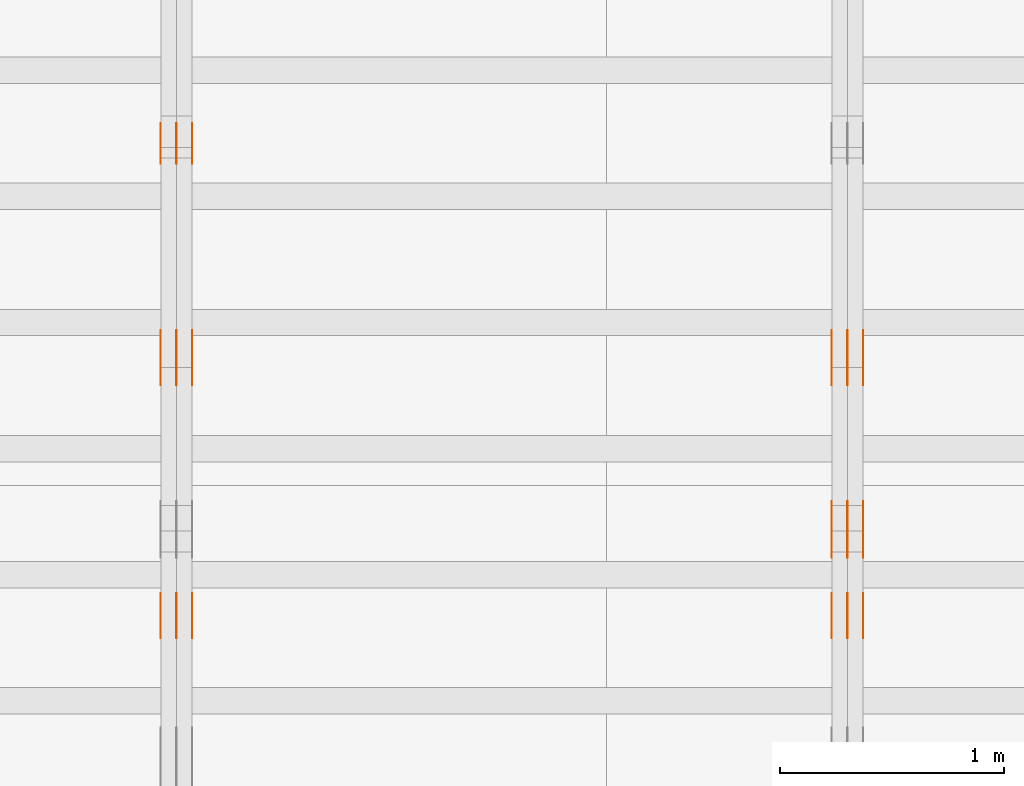
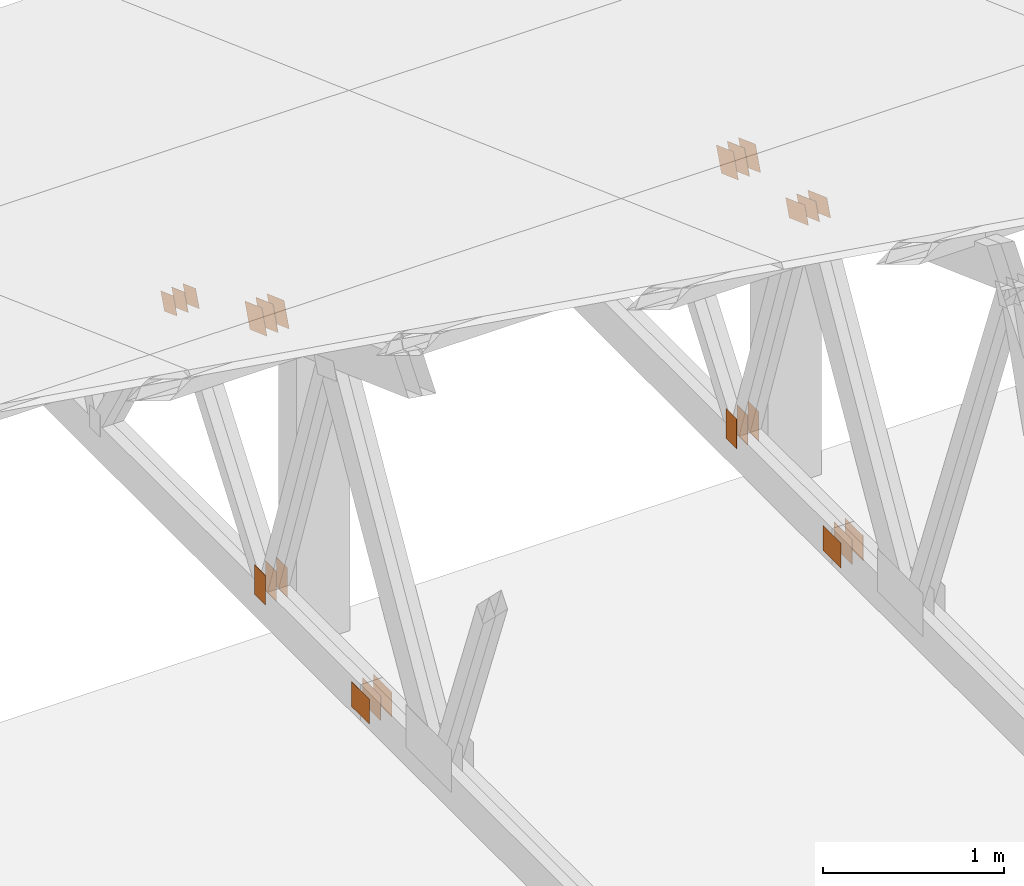
# One storey, part 126 of 189: 32 proxies.
"""IFC2X3 building model written with IfcOpenShell, lengths in millimetres."""

from ifc_helpers import new_model, entity, si_unit, converted_unit, derived_unit, direction, frame, origin, origin_2d_with_axis, place, context, subcontext, project, spatial, polyline, rectangle, outline, extrude, source, transform, mapped, material, type_object, type_shapes, element, save


model = new_model("IFC2X3")

# Units and contexts
model_context = context("Model", 3, precision=0.01, world=origin(), true_north=direction((6.12303176911189e-17, 1.0)))
body_context = subcontext(model_context, "Body", "Model", "MODEL_VIEW")
ifc_project = project(units=[si_unit("LENGTHUNIT", "METRE", prefix="MILLI"), si_unit("AREAUNIT", "SQUARE_METRE"), si_unit("VOLUMEUNIT", "CUBIC_METRE"), converted_unit("PLANEANGLEUNIT", "DEGREE", entity("IfcRatioMeasure", 0.0174532925199433), si_unit("PLANEANGLEUNIT", "RADIAN"), dimensions=[0, 0, 0, 0, 0, 0, 0]), si_unit("MASSUNIT", "GRAM", prefix="KILO"), derived_unit("MASSDENSITYUNIT", [(si_unit("MASSUNIT", "GRAM", prefix="KILO"), 1), (si_unit("LENGTHUNIT", "METRE"), -3)]), si_unit("TIMEUNIT", "SECOND"), si_unit("FREQUENCYUNIT", "HERTZ"), si_unit("THERMODYNAMICTEMPERATUREUNIT", "DEGREE_CELSIUS"), derived_unit("THERMALTRANSMITTANCEUNIT", [(si_unit("MASSUNIT", "GRAM", prefix="KILO"), 1), (si_unit("THERMODYNAMICTEMPERATUREUNIT", "KELVIN"), -1), (si_unit("TIMEUNIT", "SECOND"), -3)]), derived_unit("VOLUMETRICFLOWRATEUNIT", [(si_unit("LENGTHUNIT", "METRE"), 3), (si_unit("TIMEUNIT", "SECOND"), -1)]), si_unit("ELECTRICCURRENTUNIT", "AMPERE"), si_unit("ELECTRICVOLTAGEUNIT", "VOLT"), si_unit("POWERUNIT", "WATT"), si_unit("FORCEUNIT", "NEWTON"), si_unit("ILLUMINANCEUNIT", "LUX"), si_unit("LUMINOUSFLUXUNIT", "LUMEN"), si_unit("LUMINOUSINTENSITYUNIT", "CANDELA"), derived_unit("USERDEFINED", [(si_unit("MASSUNIT", "GRAM", prefix="KILO"), -1), (si_unit("LENGTHUNIT", "METRE"), -2), (si_unit("TIMEUNIT", "SECOND"), 3), (si_unit("LUMINOUSFLUXUNIT", "LUMEN"), 1)]), derived_unit("LINEARVELOCITYUNIT", [(si_unit("LENGTHUNIT", "METRE"), 1), (si_unit("TIMEUNIT", "SECOND"), -1)]), si_unit("PRESSUREUNIT", "PASCAL"), derived_unit("USERDEFINED", [(si_unit("LENGTHUNIT", "METRE"), -2), (si_unit("MASSUNIT", "GRAM", prefix="KILO"), 1), (si_unit("TIMEUNIT", "SECOND"), -2)])], contexts=[model_context])

# Site, building, storey
site_placement = place(None, origin())
site = spatial("IfcSite", under=ifc_project, at=site_placement, CompositionType="ELEMENT")
building_placement = place(site_placement, origin())
building = spatial("IfcBuilding", under=site, at=building_placement, CompositionType="ELEMENT")
storey_placement = place(building_placement, origin())
storey = spatial("IfcBuildingStorey", under=building, at=storey_placement, Name="Default", CompositionType="ELEMENT", Elevation=0.0)

# Proxies
ifc_material_1 = material(Name="IfcSurfaceStyle #106478")
building_element_proxy_type_1 = type_object("IfcBuildingElementProxyType", PredefinedType="NOTDEFINED", material=ifc_material_1)
shared_shape_1 = source(origin(), body_context, "Body", "SweptSolid", [
    extrude(outline(polyline([(-112.499846801582, -59.999986193028), (112.499924372729, -59.999986193028), (112.499888552087, 59.999986193028), (-112.499966123235, 59.999986193028), (-112.499846801582, -59.999986193028)])), frame((112.499989807712, 60.0001003787081, 0.0), z_axis=(0.0, 0.0, 1.0), x_axis=(-1.0, 0.0, 0.0)), (0.0, 0.0, 1.0), 1.3),
])
type_shapes(building_element_proxy_type_1, [shared_shape_1])
proxy_1_placement = place(building_placement, frame((18301.3, 24040.8868138992, 2049.61031693104), z_axis=(-1.0, 0.0, 0.0), x_axis=(0.0, -0.939692620785908, 0.342020143325669)))
element("IfcBuildingElementProxy", 1, at=proxy_1_placement, inside=storey, type_object=building_element_proxy_type_1, material=ifc_material_1, context=body_context, shape_type="MappedRepresentation", body=[
    mapped(shared_shape_1, transform((0.0, 0.0, 0.0), scale=1.0)),
])
ifc_material_2 = material(Name="IfcSurfaceStyle #106421")
building_element_proxy_type_2 = type_object("IfcBuildingElementProxyType", PredefinedType="NOTDEFINED", material=ifc_material_2)
shared_shape_2 = source(origin(), body_context, "Body", "SweptSolid", [
    extrude(outline(polyline([(-112.499846801582, -59.999986193028), (112.499924372729, -59.999986193028), (112.499888552087, 59.999986193028), (-112.499966123235, 59.999986193028), (-112.499846801582, -59.999986193028)])), frame((112.499989807712, 60.0001003787081, 0.0), z_axis=(0.0, 0.0, 1.0), x_axis=(-1.0, 0.0, 0.0)), (0.0, 0.0, 1.0), 1.29999999999998),
])
type_shapes(building_element_proxy_type_2, [shared_shape_2])
proxy_2_placement = place(building_placement, frame((18230.0, 24040.8868138992, 2049.61031693104), z_axis=(-1.0, 0.0, 0.0), x_axis=(0.0, -0.939692620785908, 0.342020143325669)))
element("IfcBuildingElementProxy", 2, at=proxy_2_placement, inside=storey, type_object=building_element_proxy_type_2, material=ifc_material_2, context=body_context, shape_type="MappedRepresentation", body=[
    mapped(shared_shape_2, transform((0.0, 0.0, 0.0), scale=1.0)),
])
ifc_material_3 = material(Name="IfcSurfaceStyle #106364")
building_element_proxy_type_3 = type_object("IfcBuildingElementProxyType", PredefinedType="NOTDEFINED", material=ifc_material_3)
shared_shape_3 = source(origin(), body_context, "Body", "SweptSolid", [
    extrude(outline(polyline([(-112.499846801582, -59.999986193028), (112.499924372729, -59.999986193028), (112.499888552087, 59.999986193028), (-112.499966123235, 59.999986193028), (-112.499846801582, -59.999986193028)])), frame((112.499989807712, 60.0001003787081, 0.0), z_axis=(0.0, 0.0, 1.0), x_axis=(-1.0, 0.0, 0.0)), (0.0, 0.0, 1.0), 1.29999999999998),
])
type_shapes(building_element_proxy_type_3, [shared_shape_3])
proxy_3_placement = place(building_placement, frame((18231.3, 24040.8868138992, 2049.61031693104), z_axis=(-1.0, 0.0, 0.0), x_axis=(0.0, -0.939692620785908, 0.342020143325669)))
element("IfcBuildingElementProxy", 3, at=proxy_3_placement, inside=storey, type_object=building_element_proxy_type_3, material=ifc_material_3, context=body_context, shape_type="MappedRepresentation", body=[
    mapped(shared_shape_3, transform((0.0, 0.0, 0.0), scale=1.0)),
])
ifc_material_4 = material(Name="IfcSurfaceStyle #106307")
building_element_proxy_type_4 = type_object("IfcBuildingElementProxyType", PredefinedType="NOTDEFINED", material=ifc_material_4)
shared_shape_4 = source(origin(), body_context, "Body", "SweptSolid", [
    extrude(outline(polyline([(-112.499846801582, -59.999986193028), (112.499924372729, -59.999986193028), (112.499888552087, 59.999986193028), (-112.499966123235, 59.999986193028), (-112.499846801582, -59.999986193028)])), frame((112.499989807712, 60.0001003787081, 0.0), z_axis=(0.0, 0.0, 1.0), x_axis=(-1.0, 0.0, 0.0)), (0.0, 0.0, 1.0), 1.29999999999999),
])
type_shapes(building_element_proxy_type_4, [shared_shape_4])
proxy_4_placement = place(building_placement, frame((18160.0, 24040.8868138992, 2049.61031693104), z_axis=(-1.0, 0.0, 0.0), x_axis=(0.0, -0.939692620785908, 0.342020143325669)))
element("IfcBuildingElementProxy", 4, at=proxy_4_placement, inside=storey, type_object=building_element_proxy_type_4, material=ifc_material_4, context=body_context, shape_type="MappedRepresentation", body=[
    mapped(shared_shape_4, transform((0.0, 0.0, 0.0), scale=1.0)),
])
ifc_material_5 = material(Name="IfcSurfaceStyle #106250")
building_element_proxy_type_5 = type_object("IfcBuildingElementProxyType", PredefinedType="NOTDEFINED", material=ifc_material_5)
shared_shape_5 = source(origin(), body_context, "Body", "SweptSolid", [
    extrude(rectangle(XDim=200.0, YDim=120.0, at=origin_2d_with_axis()), frame((100.0, 60.0002296775929, 0.0), z_axis=(0.0, 0.0, 1.0), x_axis=(-1.0, 0.0, 0.0)), (0.0, 0.0, 1.0), 1.3),
])
type_shapes(building_element_proxy_type_5, [shared_shape_5])
proxy_5_placement = place(building_placement, frame((18301.3, 24619.3435203224, 145.0), z_axis=(-1.0, 0.0, 0.0), x_axis=(0.0, 0.0, 1.0)))
element("IfcBuildingElementProxy", 5, at=proxy_5_placement, inside=storey, type_object=building_element_proxy_type_5, material=ifc_material_5, context=body_context, shape_type="MappedRepresentation", body=[
    mapped(shared_shape_5, transform((0.0, 0.0, 0.0), scale=1.0)),
])
ifc_material_6 = material(Name="IfcSurfaceStyle #106193")
building_element_proxy_type_6 = type_object("IfcBuildingElementProxyType", PredefinedType="NOTDEFINED", material=ifc_material_6)
shared_shape_6 = source(origin(), body_context, "Body", "SweptSolid", [
    extrude(rectangle(XDim=200.0, YDim=120.0, at=origin_2d_with_axis()), frame((100.0, 60.0002296775929, 0.0), z_axis=(0.0, 0.0, 1.0), x_axis=(-1.0, 0.0, 0.0)), (0.0, 0.0, 1.0), 1.29999999999998),
])
type_shapes(building_element_proxy_type_6, [shared_shape_6])
proxy_6_placement = place(building_placement, frame((18230.0, 24619.3435203224, 145.0), z_axis=(-1.0, 0.0, 0.0), x_axis=(0.0, 0.0, 1.0)))
element("IfcBuildingElementProxy", 6, at=proxy_6_placement, inside=storey, type_object=building_element_proxy_type_6, material=ifc_material_6, context=body_context, shape_type="MappedRepresentation", body=[
    mapped(shared_shape_6, transform((0.0, 0.0, 0.0), scale=1.0)),
])
ifc_material_7 = material(Name="IfcSurfaceStyle #106136")
building_element_proxy_type_7 = type_object("IfcBuildingElementProxyType", PredefinedType="NOTDEFINED", material=ifc_material_7)
shared_shape_7 = source(origin(), body_context, "Body", "SweptSolid", [
    extrude(rectangle(XDim=200.0, YDim=120.0, at=origin_2d_with_axis()), frame((100.0, 60.0002296775929, 0.0), z_axis=(0.0, 0.0, 1.0), x_axis=(-1.0, 0.0, 0.0)), (0.0, 0.0, 1.0), 1.29999999999998),
])
type_shapes(building_element_proxy_type_7, [shared_shape_7])
proxy_7_placement = place(building_placement, frame((18231.3, 24619.3435203224, 145.0), z_axis=(-1.0, 0.0, 0.0), x_axis=(0.0, 0.0, 1.0)))
element("IfcBuildingElementProxy", 7, at=proxy_7_placement, inside=storey, type_object=building_element_proxy_type_7, material=ifc_material_7, context=body_context, shape_type="MappedRepresentation", body=[
    mapped(shared_shape_7, transform((0.0, 0.0, 0.0), scale=1.0)),
])
ifc_material_8 = material(Name="IfcSurfaceStyle #106079")
building_element_proxy_type_8 = type_object("IfcBuildingElementProxyType", PredefinedType="NOTDEFINED", material=ifc_material_8)
shared_shape_8 = source(origin(), body_context, "Body", "SweptSolid", [
    extrude(rectangle(XDim=200.0, YDim=120.0, at=origin_2d_with_axis()), frame((100.0, 60.0002296775929, 0.0), z_axis=(0.0, 0.0, 1.0), x_axis=(-1.0, 0.0, 0.0)), (0.0, 0.0, 1.0), 1.29999999999999),
])
type_shapes(building_element_proxy_type_8, [shared_shape_8])
proxy_8_placement = place(building_placement, frame((18160.0, 24619.3435203224, 145.0), z_axis=(-1.0, 0.0, 0.0), x_axis=(0.0, 0.0, 1.0)))
element("IfcBuildingElementProxy", 8, at=proxy_8_placement, inside=storey, type_object=building_element_proxy_type_8, material=ifc_material_8, context=body_context, shape_type="MappedRepresentation", body=[
    mapped(shared_shape_8, transform((0.0, 0.0, 0.0), scale=1.0)),
])
ifc_material_9 = material(Name="IfcSurfaceStyle #102602")
building_element_proxy_type_9 = type_object("IfcBuildingElementProxyType", PredefinedType="NOTDEFINED", material=ifc_material_9)
shared_shape_9 = source(origin(), body_context, "Body", "SweptSolid", [
    extrude(rectangle(XDim=200.0, YDim=168.0, at=origin_2d_with_axis()), frame((100.0, 84.0, 0.0), z_axis=(0.0, 0.0, 1.0), x_axis=(-1.0, 0.0, 0.0)), (0.0, 0.0, 1.0), 1.3),
])
type_shapes(building_element_proxy_type_9, [shared_shape_9])
proxy_9_placement = place(building_placement, frame((18301.3, 23470.0, 206.5), z_axis=(-1.0, 0.0, 0.0), x_axis=(0.0, 1.0, 0.0)))
element("IfcBuildingElementProxy", 9, at=proxy_9_placement, inside=storey, type_object=building_element_proxy_type_9, material=ifc_material_9, context=body_context, shape_type="MappedRepresentation", body=[
    mapped(shared_shape_9, transform((0.0, 0.0, 0.0), scale=1.0)),
])
ifc_material_10 = material(Name="IfcSurfaceStyle #102545")
building_element_proxy_type_10 = type_object("IfcBuildingElementProxyType", PredefinedType="NOTDEFINED", material=ifc_material_10)
shared_shape_10 = source(origin(), body_context, "Body", "SweptSolid", [
    extrude(rectangle(XDim=200.0, YDim=168.0, at=origin_2d_with_axis()), frame((100.0, 84.0, 0.0), z_axis=(0.0, 0.0, 1.0), x_axis=(-1.0, 0.0, 0.0)), (0.0, 0.0, 1.0), 1.29999999999998),
])
type_shapes(building_element_proxy_type_10, [shared_shape_10])
proxy_10_placement = place(building_placement, frame((18230.0, 23470.0, 206.5), z_axis=(-1.0, 0.0, 0.0), x_axis=(0.0, 1.0, 0.0)))
element("IfcBuildingElementProxy", 10, at=proxy_10_placement, inside=storey, type_object=building_element_proxy_type_10, material=ifc_material_10, context=body_context, shape_type="MappedRepresentation", body=[
    mapped(shared_shape_10, transform((0.0, 0.0, 0.0), scale=1.0)),
])
ifc_material_11 = material(Name="IfcSurfaceStyle #102488")
building_element_proxy_type_11 = type_object("IfcBuildingElementProxyType", PredefinedType="NOTDEFINED", material=ifc_material_11)
shared_shape_11 = source(origin(), body_context, "Body", "SweptSolid", [
    extrude(rectangle(XDim=200.0, YDim=168.0, at=origin_2d_with_axis()), frame((100.0, 84.0, 0.0), z_axis=(0.0, 0.0, 1.0), x_axis=(-1.0, 0.0, 0.0)), (0.0, 0.0, 1.0), 1.29999999999998),
])
type_shapes(building_element_proxy_type_11, [shared_shape_11])
proxy_11_placement = place(building_placement, frame((18231.3, 23470.0, 206.5), z_axis=(-1.0, 0.0, 0.0), x_axis=(0.0, 1.0, 0.0)))
element("IfcBuildingElementProxy", 11, at=proxy_11_placement, inside=storey, type_object=building_element_proxy_type_11, material=ifc_material_11, context=body_context, shape_type="MappedRepresentation", body=[
    mapped(shared_shape_11, transform((0.0, 0.0, 0.0), scale=1.0)),
])
ifc_material_12 = material(Name="IfcSurfaceStyle #102431")
building_element_proxy_type_12 = type_object("IfcBuildingElementProxyType", PredefinedType="NOTDEFINED", material=ifc_material_12)
shared_shape_12 = source(origin(), body_context, "Body", "SweptSolid", [
    extrude(rectangle(XDim=200.0, YDim=168.0, at=origin_2d_with_axis()), frame((100.0, 84.0, 0.0), z_axis=(0.0, 0.0, 1.0), x_axis=(-1.0, 0.0, 0.0)), (0.0, 0.0, 1.0), 1.29999999999999),
])
type_shapes(building_element_proxy_type_12, [shared_shape_12])
proxy_12_placement = place(building_placement, frame((18160.0, 23470.0, 206.5), z_axis=(-1.0, 0.0, 0.0), x_axis=(0.0, 1.0, 0.0)))
element("IfcBuildingElementProxy", 12, at=proxy_12_placement, inside=storey, type_object=building_element_proxy_type_12, material=ifc_material_12, context=body_context, shape_type="MappedRepresentation", body=[
    mapped(shared_shape_12, transform((0.0, 0.0, 0.0), scale=1.0)),
])
ifc_material_13 = material(Name="IfcSurfaceStyle #100442")
building_element_proxy_type_13 = type_object("IfcBuildingElementProxyType", PredefinedType="NOTDEFINED", material=ifc_material_13)
shared_shape_13 = source(origin(), body_context, "Body", "SweptSolid", [
    extrude(outline(polyline([(-99.9999065788418, -84.0000755647729), (99.9999734279406, -84.0000755647729), (99.9999483293475, 84.000075564773), (-100.000015178446, 84.000075564773), (-99.9999065788418, -84.0000755647729)])), frame((100.000157783747, 84.0001144608011, 0.0), z_axis=(0.0, 0.0, 1.0), x_axis=(-1.0, 0.0, 0.0)), (0.0, 0.0, 1.0), 1.3),
])
type_shapes(building_element_proxy_type_13, [shared_shape_13])
proxy_13_placement = place(building_placement, frame((18301.3, 24788.4767593228, 1895.10136879206), z_axis=(-1.0, 0.0, 0.0), x_axis=(0.0, -0.939692620785908, 0.342020143325669)))
element("IfcBuildingElementProxy", 13, at=proxy_13_placement, inside=storey, type_object=building_element_proxy_type_13, material=ifc_material_13, context=body_context, shape_type="MappedRepresentation", body=[
    mapped(shared_shape_13, transform((0.0, 0.0, 0.0), scale=1.0)),
])
ifc_material_14 = material(Name="IfcSurfaceStyle #100385")
building_element_proxy_type_14 = type_object("IfcBuildingElementProxyType", PredefinedType="NOTDEFINED", material=ifc_material_14)
shared_shape_14 = source(origin(), body_context, "Body", "SweptSolid", [
    extrude(outline(polyline([(-99.9999065788418, -84.0000755647729), (99.9999734279406, -84.0000755647729), (99.9999483293475, 84.000075564773), (-100.000015178446, 84.000075564773), (-99.9999065788418, -84.0000755647729)])), frame((100.000157783747, 84.0001144608011, 0.0), z_axis=(0.0, 0.0, 1.0), x_axis=(-1.0, 0.0, 0.0)), (0.0, 0.0, 1.0), 1.29999999999998),
])
type_shapes(building_element_proxy_type_14, [shared_shape_14])
proxy_14_placement = place(building_placement, frame((18230.0, 24788.4767593228, 1895.10136879206), z_axis=(-1.0, 0.0, 0.0), x_axis=(0.0, -0.939692620785908, 0.342020143325669)))
element("IfcBuildingElementProxy", 14, at=proxy_14_placement, inside=storey, type_object=building_element_proxy_type_14, material=ifc_material_14, context=body_context, shape_type="MappedRepresentation", body=[
    mapped(shared_shape_14, transform((0.0, 0.0, 0.0), scale=1.0)),
])
ifc_material_15 = material(Name="IfcSurfaceStyle #100328")
building_element_proxy_type_15 = type_object("IfcBuildingElementProxyType", PredefinedType="NOTDEFINED", material=ifc_material_15)
shared_shape_15 = source(origin(), body_context, "Body", "SweptSolid", [
    extrude(outline(polyline([(-99.9999065788418, -84.0000755647729), (99.9999734279406, -84.0000755647729), (99.9999483293475, 84.000075564773), (-100.000015178446, 84.000075564773), (-99.9999065788418, -84.0000755647729)])), frame((100.000157783747, 84.0001144608011, 0.0), z_axis=(0.0, 0.0, 1.0), x_axis=(-1.0, 0.0, 0.0)), (0.0, 0.0, 1.0), 1.29999999999998),
])
type_shapes(building_element_proxy_type_15, [shared_shape_15])
proxy_15_placement = place(building_placement, frame((18231.3, 24788.4767593228, 1895.10136879206), z_axis=(-1.0, 0.0, 0.0), x_axis=(0.0, -0.939692620785908, 0.342020143325669)))
element("IfcBuildingElementProxy", 15, at=proxy_15_placement, inside=storey, type_object=building_element_proxy_type_15, material=ifc_material_15, context=body_context, shape_type="MappedRepresentation", body=[
    mapped(shared_shape_15, transform((0.0, 0.0, 0.0), scale=1.0)),
])
ifc_material_16 = material(Name="IfcSurfaceStyle #100271")
building_element_proxy_type_16 = type_object("IfcBuildingElementProxyType", PredefinedType="NOTDEFINED", material=ifc_material_16)
shared_shape_16 = source(origin(), body_context, "Body", "SweptSolid", [
    extrude(outline(polyline([(-99.9999065788418, -84.0000755647729), (99.9999734279406, -84.0000755647729), (99.9999483293475, 84.000075564773), (-100.000015178446, 84.000075564773), (-99.9999065788418, -84.0000755647729)])), frame((100.000157783747, 84.0001144608011, 0.0), z_axis=(0.0, 0.0, 1.0), x_axis=(-1.0, 0.0, 0.0)), (0.0, 0.0, 1.0), 1.29999999999999),
])
type_shapes(building_element_proxy_type_16, [shared_shape_16])
proxy_16_placement = place(building_placement, frame((18160.0, 24788.4767593228, 1895.10136879206), z_axis=(-1.0, 0.0, 0.0), x_axis=(0.0, -0.939692620785908, 0.342020143325669)))
element("IfcBuildingElementProxy", 16, at=proxy_16_placement, inside=storey, type_object=building_element_proxy_type_16, material=ifc_material_16, context=body_context, shape_type="MappedRepresentation", body=[
    mapped(shared_shape_16, transform((0.0, 0.0, 0.0), scale=1.0)),
])
ifc_material_17 = material(Name="IfcSurfaceStyle #90460")
building_element_proxy_type_17 = type_object("IfcBuildingElementProxyType", PredefinedType="NOTDEFINED", material=ifc_material_17)
shared_shape_17 = source(origin(), body_context, "Body", "SweptSolid", [
    extrude(rectangle(XDim=200.0, YDim=120.0, at=origin_2d_with_axis()), frame((100.0, 60.0002296775929, 0.0), z_axis=(0.0, 0.0, 1.0), x_axis=(-1.0, 0.0, 0.0)), (0.0, 0.0, 1.0), 1.3),
])
type_shapes(building_element_proxy_type_17, [shared_shape_17])
proxy_17_placement = place(building_placement, frame((15301.3, 24619.3435203224, 145.0), z_axis=(-1.0, 0.0, 0.0), x_axis=(0.0, 0.0, 1.0)))
element("IfcBuildingElementProxy", 17, at=proxy_17_placement, inside=storey, type_object=building_element_proxy_type_17, material=ifc_material_17, context=body_context, shape_type="MappedRepresentation", body=[
    mapped(shared_shape_17, transform((0.0, 0.0, 0.0), scale=1.0)),
])
ifc_material_18 = material(Name="IfcSurfaceStyle #90403")
building_element_proxy_type_18 = type_object("IfcBuildingElementProxyType", PredefinedType="NOTDEFINED", material=ifc_material_18)
shared_shape_18 = source(origin(), body_context, "Body", "SweptSolid", [
    extrude(rectangle(XDim=200.0, YDim=120.0, at=origin_2d_with_axis()), frame((100.0, 60.0002296775929, 0.0), z_axis=(0.0, 0.0, 1.0), x_axis=(-1.0, 0.0, 0.0)), (0.0, 0.0, 1.0), 1.29999999999998),
])
type_shapes(building_element_proxy_type_18, [shared_shape_18])
proxy_18_placement = place(building_placement, frame((15230.0, 24619.3435203224, 145.0), z_axis=(-1.0, 0.0, 0.0), x_axis=(0.0, 0.0, 1.0)))
element("IfcBuildingElementProxy", 18, at=proxy_18_placement, inside=storey, type_object=building_element_proxy_type_18, material=ifc_material_18, context=body_context, shape_type="MappedRepresentation", body=[
    mapped(shared_shape_18, transform((0.0, 0.0, 0.0), scale=1.0)),
])
ifc_material_19 = material(Name="IfcSurfaceStyle #90346")
building_element_proxy_type_19 = type_object("IfcBuildingElementProxyType", PredefinedType="NOTDEFINED", material=ifc_material_19)
shared_shape_19 = source(origin(), body_context, "Body", "SweptSolid", [
    extrude(rectangle(XDim=200.0, YDim=120.0, at=origin_2d_with_axis()), frame((100.0, 60.0002296775929, 0.0), z_axis=(0.0, 0.0, 1.0), x_axis=(-1.0, 0.0, 0.0)), (0.0, 0.0, 1.0), 1.29999999999998),
])
type_shapes(building_element_proxy_type_19, [shared_shape_19])
proxy_19_placement = place(building_placement, frame((15231.3, 24619.3435203224, 145.0), z_axis=(-1.0, 0.0, 0.0), x_axis=(0.0, 0.0, 1.0)))
element("IfcBuildingElementProxy", 19, at=proxy_19_placement, inside=storey, type_object=building_element_proxy_type_19, material=ifc_material_19, context=body_context, shape_type="MappedRepresentation", body=[
    mapped(shared_shape_19, transform((0.0, 0.0, 0.0), scale=1.0)),
])
ifc_material_20 = material(Name="IfcSurfaceStyle #90289")
building_element_proxy_type_20 = type_object("IfcBuildingElementProxyType", PredefinedType="NOTDEFINED", material=ifc_material_20)
shared_shape_20 = source(origin(), body_context, "Body", "SweptSolid", [
    extrude(rectangle(XDim=200.0, YDim=120.0, at=origin_2d_with_axis()), frame((100.0, 60.0002296775929, 0.0), z_axis=(0.0, 0.0, 1.0), x_axis=(-1.0, 0.0, 0.0)), (0.0, 0.0, 1.0), 1.29999999999999),
])
type_shapes(building_element_proxy_type_20, [shared_shape_20])
proxy_20_placement = place(building_placement, frame((15160.0, 24619.3435203224, 145.0), z_axis=(-1.0, 0.0, 0.0), x_axis=(0.0, 0.0, 1.0)))
element("IfcBuildingElementProxy", 20, at=proxy_20_placement, inside=storey, type_object=building_element_proxy_type_20, material=ifc_material_20, context=body_context, shape_type="MappedRepresentation", body=[
    mapped(shared_shape_20, transform((0.0, 0.0, 0.0), scale=1.0)),
])
ifc_material_21 = material(Name="IfcSurfaceStyle #89776")
building_element_proxy_type_21 = type_object("IfcBuildingElementProxyType", PredefinedType="NOTDEFINED", material=ifc_material_21)
shared_shape_21 = source(origin(), body_context, "Body", "SweptSolid", [
    extrude(outline(polyline([(-74.9999475298494, -60.0), (75.0000042257432, -60.0), (74.9999684051025, 60.0), (-75.0000251009963, 60.0), (-74.9999475298494, -60.0)])), frame((75.0000607644577, 60.0000865490217, 0.0), z_axis=(0.0, 0.0, 1.0), x_axis=(-1.0, 0.0, 0.0)), (0.0, 0.0, 1.0), 1.3),
])
type_shapes(building_element_proxy_type_21, [shared_shape_21])
proxy_21_placement = place(building_placement, frame((15301.3, 25732.0586805394, 1446.84420669249), z_axis=(-1.0, 0.0, 0.0), x_axis=(0.0, -0.939692620785908, 0.342020143325669)))
element("IfcBuildingElementProxy", 21, at=proxy_21_placement, inside=storey, type_object=building_element_proxy_type_21, material=ifc_material_21, context=body_context, shape_type="MappedRepresentation", body=[
    mapped(shared_shape_21, transform((0.0, 0.0, 0.0), scale=1.0)),
])
ifc_material_22 = material(Name="IfcSurfaceStyle #89719")
building_element_proxy_type_22 = type_object("IfcBuildingElementProxyType", PredefinedType="NOTDEFINED", material=ifc_material_22)
shared_shape_22 = source(origin(), body_context, "Body", "SweptSolid", [
    extrude(outline(polyline([(-74.9999475298494, -60.0), (75.0000042257432, -60.0), (74.9999684051025, 60.0), (-75.0000251009963, 60.0), (-74.9999475298494, -60.0)])), frame((75.0000607644577, 60.0000865490217, 0.0), z_axis=(0.0, 0.0, 1.0), x_axis=(-1.0, 0.0, 0.0)), (0.0, 0.0, 1.0), 1.29999999999999),
])
type_shapes(building_element_proxy_type_22, [shared_shape_22])
proxy_22_placement = place(building_placement, frame((15230.0, 25732.0586805394, 1446.84420669249), z_axis=(-1.0, 0.0, 0.0), x_axis=(0.0, -0.939692620785908, 0.342020143325669)))
element("IfcBuildingElementProxy", 22, at=proxy_22_placement, inside=storey, type_object=building_element_proxy_type_22, material=ifc_material_22, context=body_context, shape_type="MappedRepresentation", body=[
    mapped(shared_shape_22, transform((0.0, 0.0, 0.0), scale=1.0)),
])
ifc_material_23 = material(Name="IfcSurfaceStyle #89662")
building_element_proxy_type_23 = type_object("IfcBuildingElementProxyType", PredefinedType="NOTDEFINED", material=ifc_material_23)
shared_shape_23 = source(origin(), body_context, "Body", "SweptSolid", [
    extrude(outline(polyline([(-74.9999475298494, -60.0), (75.0000042257432, -60.0), (74.9999684051025, 60.0), (-75.0000251009963, 60.0), (-74.9999475298494, -60.0)])), frame((75.0000607644577, 60.0000865490217, 0.0), z_axis=(0.0, 0.0, 1.0), x_axis=(-1.0, 0.0, 0.0)), (0.0, 0.0, 1.0), 1.29999999999999),
])
type_shapes(building_element_proxy_type_23, [shared_shape_23])
proxy_23_placement = place(building_placement, frame((15231.3, 25732.0586805394, 1446.84420669249), z_axis=(-1.0, 0.0, 0.0), x_axis=(0.0, -0.939692620785908, 0.342020143325669)))
element("IfcBuildingElementProxy", 23, at=proxy_23_placement, inside=storey, type_object=building_element_proxy_type_23, material=ifc_material_23, context=body_context, shape_type="MappedRepresentation", body=[
    mapped(shared_shape_23, transform((0.0, 0.0, 0.0), scale=1.0)),
])
ifc_material_24 = material(Name="IfcSurfaceStyle #89605")
building_element_proxy_type_24 = type_object("IfcBuildingElementProxyType", PredefinedType="NOTDEFINED", material=ifc_material_24)
shared_shape_24 = source(origin(), body_context, "Body", "SweptSolid", [
    extrude(outline(polyline([(-74.9999475298494, -60.0), (75.0000042257432, -60.0), (74.9999684051025, 60.0), (-75.0000251009963, 60.0), (-74.9999475298494, -60.0)])), frame((75.0000607644577, 60.0000865490217, 0.0), z_axis=(0.0, 0.0, 1.0), x_axis=(-1.0, 0.0, 0.0)), (0.0, 0.0, 1.0), 1.29999999999999),
])
type_shapes(building_element_proxy_type_24, [shared_shape_24])
proxy_24_placement = place(building_placement, frame((15160.0, 25732.0586805394, 1446.84420669249), z_axis=(-1.0, 0.0, 0.0), x_axis=(0.0, -0.939692620785908, 0.342020143325669)))
element("IfcBuildingElementProxy", 24, at=proxy_24_placement, inside=storey, type_object=building_element_proxy_type_24, material=ifc_material_24, context=body_context, shape_type="MappedRepresentation", body=[
    mapped(shared_shape_24, transform((0.0, 0.0, 0.0), scale=1.0)),
])
ifc_material_25 = material(Name="IfcSurfaceStyle #86812")
building_element_proxy_type_25 = type_object("IfcBuildingElementProxyType", PredefinedType="NOTDEFINED", material=ifc_material_25)
shared_shape_25 = source(origin(), body_context, "Body", "SweptSolid", [
    extrude(rectangle(XDim=200.0, YDim=168.0, at=origin_2d_with_axis()), frame((100.0, 84.0, 0.0), z_axis=(0.0, 0.0, 1.0), x_axis=(-1.0, 0.0, 0.0)), (0.0, 0.0, 1.0), 1.3),
])
type_shapes(building_element_proxy_type_25, [shared_shape_25])
proxy_25_placement = place(building_placement, frame((15301.3, 23470.0, 206.5), z_axis=(-1.0, 0.0, 0.0), x_axis=(0.0, 1.0, 0.0)))
element("IfcBuildingElementProxy", 25, at=proxy_25_placement, inside=storey, type_object=building_element_proxy_type_25, material=ifc_material_25, context=body_context, shape_type="MappedRepresentation", body=[
    mapped(shared_shape_25, transform((0.0, 0.0, 0.0), scale=1.0)),
])
ifc_material_26 = material(Name="IfcSurfaceStyle #86755")
building_element_proxy_type_26 = type_object("IfcBuildingElementProxyType", PredefinedType="NOTDEFINED", material=ifc_material_26)
shared_shape_26 = source(origin(), body_context, "Body", "SweptSolid", [
    extrude(rectangle(XDim=200.0, YDim=168.0, at=origin_2d_with_axis()), frame((100.0, 84.0, 0.0), z_axis=(0.0, 0.0, 1.0), x_axis=(-1.0, 0.0, 0.0)), (0.0, 0.0, 1.0), 1.29999999999998),
])
type_shapes(building_element_proxy_type_26, [shared_shape_26])
proxy_26_placement = place(building_placement, frame((15230.0, 23470.0, 206.5), z_axis=(-1.0, 0.0, 0.0), x_axis=(0.0, 1.0, 0.0)))
element("IfcBuildingElementProxy", 26, at=proxy_26_placement, inside=storey, type_object=building_element_proxy_type_26, material=ifc_material_26, context=body_context, shape_type="MappedRepresentation", body=[
    mapped(shared_shape_26, transform((0.0, 0.0, 0.0), scale=1.0)),
])
ifc_material_27 = material(Name="IfcSurfaceStyle #86698")
building_element_proxy_type_27 = type_object("IfcBuildingElementProxyType", PredefinedType="NOTDEFINED", material=ifc_material_27)
shared_shape_27 = source(origin(), body_context, "Body", "SweptSolid", [
    extrude(rectangle(XDim=200.0, YDim=168.0, at=origin_2d_with_axis()), frame((100.0, 84.0, 0.0), z_axis=(0.0, 0.0, 1.0), x_axis=(-1.0, 0.0, 0.0)), (0.0, 0.0, 1.0), 1.29999999999998),
])
type_shapes(building_element_proxy_type_27, [shared_shape_27])
proxy_27_placement = place(building_placement, frame((15231.3, 23470.0, 206.5), z_axis=(-1.0, 0.0, 0.0), x_axis=(0.0, 1.0, 0.0)))
element("IfcBuildingElementProxy", 27, at=proxy_27_placement, inside=storey, type_object=building_element_proxy_type_27, material=ifc_material_27, context=body_context, shape_type="MappedRepresentation", body=[
    mapped(shared_shape_27, transform((0.0, 0.0, 0.0), scale=1.0)),
])
ifc_material_28 = material(Name="IfcSurfaceStyle #86641")
building_element_proxy_type_28 = type_object("IfcBuildingElementProxyType", PredefinedType="NOTDEFINED", material=ifc_material_28)
shared_shape_28 = source(origin(), body_context, "Body", "SweptSolid", [
    extrude(rectangle(XDim=200.0, YDim=168.0, at=origin_2d_with_axis()), frame((100.0, 84.0, 0.0), z_axis=(0.0, 0.0, 1.0), x_axis=(-1.0, 0.0, 0.0)), (0.0, 0.0, 1.0), 1.29999999999999),
])
type_shapes(building_element_proxy_type_28, [shared_shape_28])
proxy_28_placement = place(building_placement, frame((15160.0, 23470.0, 206.5), z_axis=(-1.0, 0.0, 0.0), x_axis=(0.0, 1.0, 0.0)))
element("IfcBuildingElementProxy", 28, at=proxy_28_placement, inside=storey, type_object=building_element_proxy_type_28, material=ifc_material_28, context=body_context, shape_type="MappedRepresentation", body=[
    mapped(shared_shape_28, transform((0.0, 0.0, 0.0), scale=1.0)),
])
ifc_material_29 = material(Name="IfcSurfaceStyle #84652")
building_element_proxy_type_29 = type_object("IfcBuildingElementProxyType", PredefinedType="NOTDEFINED", material=ifc_material_29)
shared_shape_29 = source(origin(), body_context, "Body", "SweptSolid", [
    extrude(outline(polyline([(-99.9999065788418, -84.0000755647729), (99.9999734279406, -84.0000755647729), (99.9999483293475, 84.000075564773), (-100.000015178446, 84.000075564773), (-99.9999065788418, -84.0000755647729)])), frame((100.000157783747, 84.0001144608011, 0.0), z_axis=(0.0, 0.0, 1.0), x_axis=(-1.0, 0.0, 0.0)), (0.0, 0.0, 1.0), 1.3),
])
type_shapes(building_element_proxy_type_29, [shared_shape_29])
proxy_29_placement = place(building_placement, frame((15301.3, 24788.4767593228, 1895.10136879206), z_axis=(-1.0, 0.0, 0.0), x_axis=(0.0, -0.939692620785908, 0.342020143325669)))
element("IfcBuildingElementProxy", 29, at=proxy_29_placement, inside=storey, type_object=building_element_proxy_type_29, material=ifc_material_29, context=body_context, shape_type="MappedRepresentation", body=[
    mapped(shared_shape_29, transform((0.0, 0.0, 0.0), scale=1.0)),
])
ifc_material_30 = material(Name="IfcSurfaceStyle #84595")
building_element_proxy_type_30 = type_object("IfcBuildingElementProxyType", PredefinedType="NOTDEFINED", material=ifc_material_30)
shared_shape_30 = source(origin(), body_context, "Body", "SweptSolid", [
    extrude(outline(polyline([(-99.9999065788418, -84.0000755647729), (99.9999734279406, -84.0000755647729), (99.9999483293475, 84.000075564773), (-100.000015178446, 84.000075564773), (-99.9999065788418, -84.0000755647729)])), frame((100.000157783747, 84.0001144608011, 0.0), z_axis=(0.0, 0.0, 1.0), x_axis=(-1.0, 0.0, 0.0)), (0.0, 0.0, 1.0), 1.29999999999998),
])
type_shapes(building_element_proxy_type_30, [shared_shape_30])
proxy_30_placement = place(building_placement, frame((15230.0, 24788.4767593228, 1895.10136879206), z_axis=(-1.0, 0.0, 0.0), x_axis=(0.0, -0.939692620785908, 0.342020143325669)))
element("IfcBuildingElementProxy", 30, at=proxy_30_placement, inside=storey, type_object=building_element_proxy_type_30, material=ifc_material_30, context=body_context, shape_type="MappedRepresentation", body=[
    mapped(shared_shape_30, transform((0.0, 0.0, 0.0), scale=1.0)),
])
ifc_material_31 = material(Name="IfcSurfaceStyle #84538")
building_element_proxy_type_31 = type_object("IfcBuildingElementProxyType", PredefinedType="NOTDEFINED", material=ifc_material_31)
shared_shape_31 = source(origin(), body_context, "Body", "SweptSolid", [
    extrude(outline(polyline([(-99.9999065788418, -84.0000755647729), (99.9999734279406, -84.0000755647729), (99.9999483293475, 84.000075564773), (-100.000015178446, 84.000075564773), (-99.9999065788418, -84.0000755647729)])), frame((100.000157783747, 84.0001144608011, 0.0), z_axis=(0.0, 0.0, 1.0), x_axis=(-1.0, 0.0, 0.0)), (0.0, 0.0, 1.0), 1.29999999999998),
])
type_shapes(building_element_proxy_type_31, [shared_shape_31])
proxy_31_placement = place(building_placement, frame((15231.3, 24788.4767593228, 1895.10136879206), z_axis=(-1.0, 0.0, 0.0), x_axis=(0.0, -0.939692620785908, 0.342020143325669)))
element("IfcBuildingElementProxy", 31, at=proxy_31_placement, inside=storey, type_object=building_element_proxy_type_31, material=ifc_material_31, context=body_context, shape_type="MappedRepresentation", body=[
    mapped(shared_shape_31, transform((0.0, 0.0, 0.0), scale=1.0)),
])
ifc_material_32 = material(Name="IfcSurfaceStyle #84481")
building_element_proxy_type_32 = type_object("IfcBuildingElementProxyType", PredefinedType="NOTDEFINED", material=ifc_material_32)
shared_shape_32 = source(origin(), body_context, "Body", "SweptSolid", [
    extrude(outline(polyline([(-99.9999065788418, -84.0000755647729), (99.9999734279406, -84.0000755647729), (99.9999483293475, 84.000075564773), (-100.000015178446, 84.000075564773), (-99.9999065788418, -84.0000755647729)])), frame((100.000157783747, 84.0001144608011, 0.0), z_axis=(0.0, 0.0, 1.0), x_axis=(-1.0, 0.0, 0.0)), (0.0, 0.0, 1.0), 1.29999999999999),
])
type_shapes(building_element_proxy_type_32, [shared_shape_32])
proxy_32_placement = place(building_placement, frame((15160.0, 24788.4767593228, 1895.10136879206), z_axis=(-1.0, 0.0, 0.0), x_axis=(0.0, -0.939692620785908, 0.342020143325669)))
element("IfcBuildingElementProxy", 32, at=proxy_32_placement, inside=storey, type_object=building_element_proxy_type_32, material=ifc_material_32, context=body_context, shape_type="MappedRepresentation", body=[
    mapped(shared_shape_32, transform((0.0, 0.0, 0.0), scale=1.0)),
])

save(model, "model.ifc")
